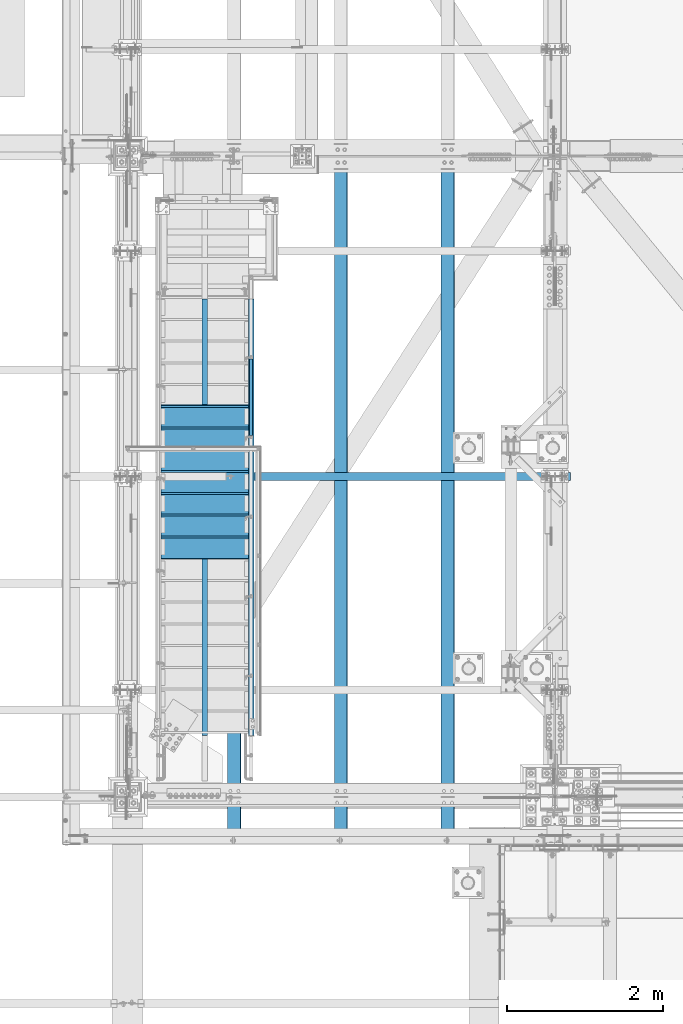
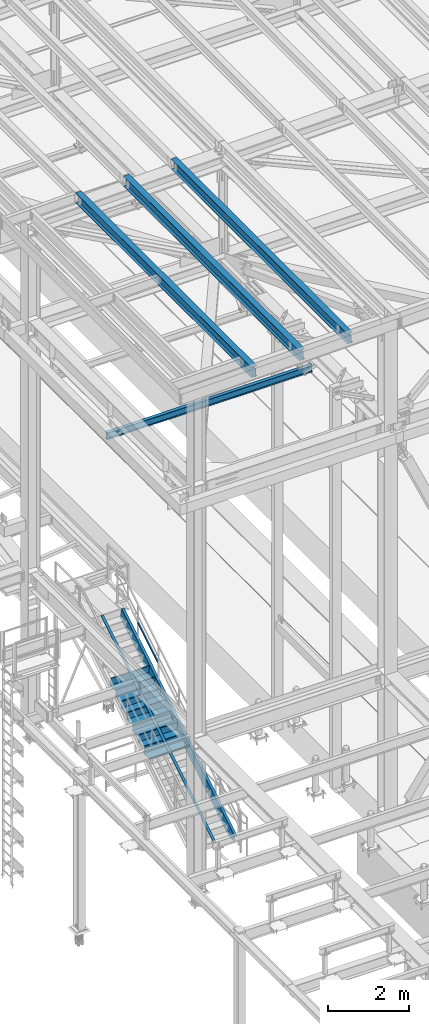
# One storey, part 1747 of 3843: 11 beams, 3 members, 7 elements without a shape of their own.
"""IFC2X3 building model written with IfcOpenShell, lengths in millimetres."""

from ifc_helpers import new_model, si_unit, frame, origin_with_axes, place, context, subcontext, project, spatial, faceted_brep, material, type_object, element, aggregate, save


model = new_model("IFC2X3")

# Units and contexts
model_context = context("Model", 3, precision=1e-05, world=origin_with_axes())
body_context = subcontext(model_context, "Body", "Model", "MODEL_VIEW")
ifc_project = project(units=[si_unit("LENGTHUNIT", "METRE", prefix="MILLI"), si_unit("AREAUNIT", "SQUARE_METRE"), si_unit("VOLUMEUNIT", "CUBIC_METRE"), si_unit("MASSUNIT", "GRAM", prefix="KILO"), si_unit("TIMEUNIT", "SECOND"), si_unit("PLANEANGLEUNIT", "RADIAN"), si_unit("SOLIDANGLEUNIT", "STERADIAN"), si_unit("THERMODYNAMICTEMPERATUREUNIT", "DEGREE_CELSIUS"), si_unit("LUMINOUSINTENSITYUNIT", "LUMEN")], contexts=[model_context])

# Site, building, storey
site_placement = place(None, origin_with_axes())
site = spatial("IfcSite", under=ifc_project, at=site_placement, CompositionType="ELEMENT")
building_placement = place(site_placement, origin_with_axes())
building = spatial("IfcBuilding", under=site, at=building_placement, Name="Undefined", CompositionType="ELEMENT")
storey_placement = place(building_placement, origin_with_axes())
storey = spatial("IfcBuildingStorey", under=building, at=storey_placement, Name="Undefined", CompositionType="ELEMENT", Elevation=0.0)

# Assembly, member
assembly_1_placement = place(storey_placement, origin_with_axes())
assembly_1 = element("IfcElementAssembly", 1, at=assembly_1_placement, inside=storey, Name="RAIL", AssemblyPlace="NOTDEFINED", PredefinedType="RIGID_FRAME")
ifc_material_1 = material()
member_type_1 = type_object("IfcMemberType", Name="HSS1-1/2X1-1/2X1/4", PredefinedType="NOTDEFINED")
member_1_placement = place(assembly_1_placement, frame((38163.499999927, 30238.7, 33562.6363637665), z_axis=(0.0, -0.529007926750979, 0.848616882600523), x_axis=(0.0, 0.848616882600524, 0.529007926750978)))
member_1 = element("IfcMember", 2, at=member_1_placement, type_object=member_type_1, material=ifc_material_1, Name="RAIL", ObjectType="HSS1-1/2X1-1/2X1/4", context=body_context, shape_type="Brep", body=[
    faceted_brep([(1194.15206246817, -19.0499999811145, 19.0499992336445), (1170.40141407416, -19.0499992350015, -19.0499992362566), (1170.40141407416, 19.0499992350015, -19.0499992362566), (1194.15206246817, 19.0499992350015, 19.0499992336445), (1190.19362096973, -12.6999993299978, 12.6999993286627), (1190.19362096973, 12.6999993299978, 12.6999993286627), (1174.35985557328, 12.6999993299978, -12.6999993312675), (1174.35985557328, -12.6999993299978, -12.6999993312675), (10.5729683018217, 19.0499992350015, -19.0499992349742), (34.3236166958304, 19.0499992350015, 19.0499992349305), (34.3236166958304, -19.0500000222455, 19.0499992349305), (10.5729683018217, -19.0499992350015, -19.0499992349742), (30.3651751973375, -12.6999993299978, 12.6999993299451), (14.5314098008821, -12.6999993299978, -12.6999993299924), (14.5314098008821, 12.6999993299978, -12.6999993299924), (30.3651751973375, 12.6999993299978, 12.6999993299451)], [[[0, 1, 2, 3], [4, 5, 6, 7]], [[8, 9, 3, 2]], [[9, 10, 0, 3]], [[10, 11, 1, 0]], [[11, 8, 2, 1]], [[10, 9, 8, 11], [12, 13, 14, 15]], [[13, 12, 4, 7]], [[14, 13, 7, 6]], [[15, 14, 6, 5]], [[12, 15, 5, 4]]]),
])
aggregate(assembly_1, [member_1])

assembly_2_placement = place(storey_placement, origin_with_axes())
assembly_2 = element("IfcElementAssembly", 3, at=assembly_2_placement, inside=storey, Name="STAIR", AssemblyPlace="NOTDEFINED", PredefinedType="RIGID_FRAME")
ifc_material_2 = material(Name="STEEL/A36")
member_type_2 = type_object("IfcMemberType", Name="C12X20.7", PredefinedType="NOTDEFINED")
member_2_placement = place(assembly_2_placement, frame((38163.5, 26304.1439046432, 30426.8707870968), z_axis=(0.0, -0.529007926750979, 0.848616882600523), x_axis=(0.0, 0.848616882600524, 0.529007926750978)))
member_2 = element("IfcMember", 4, at=member_2_placement, type_object=member_type_2, material=ifc_material_2, Name="STAIR", ObjectType="C12X20.7", context=body_context, shape_type="Brep", body=[
    faceted_brep([(340.480021051524, 30.1625000000058, -134.674927500528), (358.723458605898, -38.1000000000058, -146.047460000562), (6732.64031213429, -38.1000000000058, -146.04746000762), (6735.89472352868, 30.1625000000058, -134.674927507611), (368.913991523848, -38.1000000000058, -152.40000000058), (6730.82244275829, -38.1000000000058, -152.400000007619), (368.913991523848, 38.1000000000058, -152.40000000058), (6730.82244275829, 38.1000000000058, -152.400000007619), (6818.04528366987, -38.1000000000058, 152.399999992631), (6816.22741429387, -38.1000000000058, 146.047459992624), (6812.97300289948, 30.1625000000058, 134.674927492615), (6818.04528366987, 38.1000000000058, 152.399999992631), (211.84695601392, -38.1000000000058, 152.39999999994), (207.886931079338, -38.1000000000058, 146.047459999936), (200.797560171122, 30.1625000000058, 134.674927499931), (118.969711972852, 30.1625000000058, 3.40942099909807), (118.969711972852, 38.1000000000058, 3.40942099909807), (211.84695601392, 38.1000000000058, 152.39999999994)], [[[0, 1, 2, 3]], [[1, 4, 5, 2]], [[4, 6, 7, 5]], [[8, 9, 10, 3, 2, 5, 7, 11]], [[9, 8, 12, 13]], [[10, 9, 13, 14]], [[0, 3, 10, 14, 15]], [[6, 4, 1, 0, 15, 16]], [[11, 7, 6, 16, 17]], [[8, 11, 17, 12]], [[16, 15, 14, 13, 12, 17]]]),
])

# Assembly, beam
assembly_3_placement = place(storey_placement, origin_with_axes())
assembly_3 = element("IfcElementAssembly", 5, at=assembly_3_placement, inside=storey, Name="BEAM", AssemblyPlace="NOTDEFINED", PredefinedType="RIGID_FRAME")
ifc_material_3 = material(Name="STEEL/A992")
beam_type_1 = type_object("IfcBeamType", Name="W12X26", PredefinedType="NOTDEFINED")
beam_1_placement = place(assembly_3_placement, frame((40687.5092622718, 25006.2650649589, 45660.9713191839), z_axis=(-0.0211520975410968, -0.000224554000033095, 0.999776244139214), x_axis=(0.0, 0.999999974776521, 0.000224603999949863)))
beam_1 = element("IfcBeam", 6, at=beam_1_placement, type_object=beam_type_1, material=ifc_material_3, Name="BEAM", ObjectType="W12X26", context=body_context, shape_type="Brep", body=[
    faceted_brep([(20.6432194425361, -3.17499999977736, -130.175000003233), (20.6431892746732, 3.17500000020664, -130.175000003226), (77.7871087097046, 3.17500000020664, -130.175000002506), (77.7871087096828, -3.17499999977736, -130.175000002491), (82.6471882277765, 3.17500000020664, -131.141729925075), (82.6471882277547, -3.17499999978463, -131.141729925053), (86.767364695952, 3.17500000020664, -133.894743825527), (86.7673646959338, -3.17499999977736, -133.894743825498), (89.5203785964477, 3.17500000021391, -138.014920293645), (89.5203785964259, -3.17499999977008, -138.014920293623), (90.4871085190243, -3.1749999997628, -142.87499981164), (90.4871085190425, 3.17500000022119, -142.874999811655), (90.4871085193299, 3.17500000023574, -146.049999999443), (90.4871085193336, 82.5500000000975, -146.049999999501), (90.4871085193481, 82.550000000112, -155.57499999948), (90.4871085193408, -82.54999999961, -155.574999999364), (90.4871085193226, -82.54999999961, -146.049999999384), (90.4871085193299, -3.17499999975553, -146.049999999435), (8826.56834595945, -82.550000000505, 146.050000019059), (8826.57048483397, -82.5500000005268, 155.575000019031), (90.4871085147206, -82.5500000001266, 155.557908809169), (90.4871085147352, -82.5500000001048, 146.049999999916), (8826.56970046957, 82.549999999188, 155.575000018915), (90.4871085147315, 82.5499999995955, 155.574999999772), (8826.56756159505, 82.5499999992098, 146.050000018935), (90.4871085147461, 82.54999999961, 146.049999999792), (8826.56793869332, 3.17499999935535, 146.050000018993), (90.4871085147424, 3.17499999975553, 146.04999999985), (77.7871087051171, -3.17500000022119, 130.174999996096), (77.787108705139, 3.17499999977736, 130.174999996074), (20.7016518448945, 3.17499999978463, 130.174999995521), (20.7016820127574, -3.17500000021391, 130.174999995514), (82.6471882231817, -3.17500000021391, 131.141729918687), (82.6471882231963, 3.17499999977008, 131.141729918665), (86.7673646913427, -3.17500000022119, 133.894743819154), (86.7673646913609, 3.17499999977008, 133.894743819132), (89.5203785918275, -3.17500000022847, 138.014920287285), (89.5203785918493, 3.17499999977008, 138.014920287271), (90.4871085144187, -3.17500000022847, 142.874999805295), (90.4871085144332, 3.1749999997628, 142.874999805266), (90.4871085147424, -3.17500000023574, 146.04999999985), (8826.56796886118, -3.17500000064319, 146.050000019), (8826.50234654136, 3.17499999982101, -146.0499999803), (8826.50237670922, -3.17500000016298, -146.0499999803), (8826.50275380749, -82.5500000000247, -146.049999980249), (8826.50061493297, -82.5500000000102, -155.574999980214), (8826.49987298995, 82.5500000007232, -155.575000018347), (8826.50196944308, 82.54999999969, -146.049999980365), (20.6470195182665, 3.17500000018481, -113.117865577369), (20.6988016129581, 3.17499999980646, 117.482128609852)], [[[0, 1, 2, 3]], [[3, 2, 4, 5]], [[5, 4, 6, 7]], [[7, 6, 8, 9]], [[10, 11, 12, 13, 14, 15, 16, 17]], [[9, 8, 11, 10]], [[18, 19, 20, 21]], [[19, 22, 23, 20]], [[22, 24, 25, 23]], [[24, 26, 27, 25]], [[28, 29, 30, 31]], [[32, 33, 29, 28]], [[34, 35, 33, 32]], [[36, 37, 35, 34]], [[38, 39, 37, 36]], [[20, 23, 25, 27, 39, 38, 40, 21]], [[41, 18, 21, 40]], [[42, 26, 24, 22, 19, 18, 41, 43, 44, 45, 46, 47]], [[44, 43, 17, 16]], [[45, 44, 16, 15]], [[46, 45, 15, 14]], [[47, 46, 14, 13]], [[42, 47, 13, 12]], [[6, 4, 2, 1, 48, 49, 30, 29, 33, 35, 37, 39, 27, 26, 42, 12, 11, 8]], [[31, 30, 49, 48, 1, 0]], [[43, 41, 40, 38, 36, 34, 32, 28, 31, 0, 3, 5, 7, 9, 10, 17]]]),
])
aggregate(assembly_3, [beam_1])

assembly_4_placement = place(storey_placement, origin_with_axes())
assembly_4 = element("IfcElementAssembly", 7, at=assembly_4_placement, inside=storey, Name="BEAM", AssemblyPlace="NOTDEFINED", PredefinedType="RIGID_FRAME")
beam_2_placement = place(assembly_4_placement, frame((39315.9092622727, 25006.2767099549, 45631.9526113592), z_axis=(-0.0211520982443181, -0.000149703000020964, 0.999776258134226), x_axis=(0.0, 0.999999988789565, 0.000149735999968842)))
beam_2 = element("IfcBeam", 8, at=beam_2_placement, type_object=beam_type_1, material=ifc_material_3, Name="BEAM", ObjectType="W12X26", context=body_context, shape_type="Brep", body=[
    faceted_brep([(20.6413128908898, -3.17499999974098, -130.175000000403), (20.6412927789825, 3.17500000025029, -130.175000000381), (77.787239125093, 3.17500000024302, -130.175000000025), (77.7872391250785, -3.1749999997337, -130.174999999988), (82.6473186431285, 3.17500000025757, -131.14172992263), (82.647318643114, -3.1749999997337, -131.141729922587), (86.7674951112749, 3.17500000025757, -133.894743823133), (86.7674951112604, -3.1749999997337, -133.89474382309), (89.5205090117561, 3.17500000026484, -138.014920291324), (89.5205090117415, -3.17499999971915, -138.01492029128), (90.4872389343363, -3.17499999971187, -142.874999809348), (90.4872389343473, 3.17500000027212, -142.874999809399), (90.4872389345364, 3.1750000002794, -146.050000000265), (90.4872389345328, 82.5500000001484, -146.050000000447), (90.487238934511, 82.550000000163, -155.575000000463), (90.487238934511, -82.5499999995518, -155.575000000055), (90.4872389345401, -82.5499999995736, -146.050000000047), (90.4872389345328, -3.17499999971187, -146.050000000243), (8826.545514467, -82.5499999999593, 146.049999991854), (8826.5469403833, -82.5499999999738, 155.57499999187), (90.4872389378907, -82.5500000001557, 155.563607545781), (90.4872389379016, -82.5500000001339, 146.050000000294), (8826.54641747371, 82.549999999741, 155.57499999147), (90.4872389378834, 82.5499999995591, 155.574999999903), (8826.54499155741, 82.5499999997555, 146.049999991461), (90.4872389378979, 82.5499999995809, 146.049999999894), (8826.54524295625, 3.17499999990105, 146.04999999165), (90.4872389379016, 3.17499999972642, 146.05000000009), (77.7872391286583, -3.17500000023574, 130.175000000687), (77.7872391286764, 3.17499999975553, 130.175000000643), (20.6802678246204, 3.17499999974825, 130.174999999719), (20.6802879365277, -3.17500000023574, 130.174999999697), (82.6473186466756, -3.17500000023574, 131.141729923271), (82.6473186466901, 3.17499999974825, 131.141729923227), (86.7674951147928, -3.17500000025029, 133.894743823752), (86.767495114811, 3.17499999974825, 133.894743823708), (89.5205090152376, -3.17500000025757, 138.01492029192), (89.5205090152485, 3.1749999997337, 138.014920291876), (90.4872389377924, -3.17500000026484, 142.874999809981), (90.487238937807, 3.17499999971915, 142.874999809945), (90.4872389379016, -3.17500000026484, 146.050000000105), (8826.54526306816, -3.17500000009022, 146.049999991665), (8826.50151485627, 3.17500000045402, -146.050000008698), (8826.50153496817, -3.17499999953725, -146.050000008683), (8826.50178636701, -82.5499999993917, -146.050000008487), (8826.5003604507, -82.5499999993772, -155.575000008503), (8826.49987298995, 82.5500000007232, -155.575000018347), (8826.50126345742, 82.5500000003303, -146.050000008894), (20.643845918461, 3.17500000022119, -113.120244767728), (20.6783673143655, 3.17499999977736, 117.479752649408)], [[[0, 1, 2, 3]], [[3, 2, 4, 5]], [[5, 4, 6, 7]], [[7, 6, 8, 9]], [[10, 11, 12, 13, 14, 15, 16, 17]], [[9, 8, 11, 10]], [[18, 19, 20, 21]], [[19, 22, 23, 20]], [[22, 24, 25, 23]], [[24, 26, 27, 25]], [[28, 29, 30, 31]], [[32, 33, 29, 28]], [[34, 35, 33, 32]], [[36, 37, 35, 34]], [[38, 39, 37, 36]], [[20, 23, 25, 27, 39, 38, 40, 21]], [[41, 18, 21, 40]], [[42, 26, 24, 22, 19, 18, 41, 43, 44, 45, 46, 47]], [[44, 43, 17, 16]], [[45, 44, 16, 15]], [[46, 45, 15, 14]], [[47, 46, 14, 13]], [[42, 47, 13, 12]], [[6, 4, 2, 1, 48, 49, 30, 29, 33, 35, 37, 39, 27, 26, 42, 12, 11, 8]], [[31, 30, 49, 48, 1, 0]], [[43, 41, 40, 38, 36, 34, 32, 28, 31, 0, 3, 5, 7, 9, 10, 17]]]),
])
aggregate(assembly_4, [beam_2])

assembly_5_placement = place(storey_placement, origin_with_axes())
assembly_5 = element("IfcElementAssembly", 9, at=assembly_5_placement, inside=storey, Name="BEAM", AssemblyPlace="NOTDEFINED", PredefinedType="RIGID_FRAME")
beam_3_placement = place(assembly_5_placement, frame((37944.3092622731, 25006.2883549503, 45602.9339026668), z_axis=(-0.0211520980666537, -7.48509999611997e-05, 0.999776266544024), x_axis=(0.0, 0.999999997197391, 7.4868000015057e-05)))
beam_3 = element("IfcBeam", 10, at=beam_3_placement, type_object=beam_type_1, material=ifc_material_3, Name="BEAM", ObjectType="W12X26", context=body_context, shape_type="Brep", body=[
    faceted_brep([(20.639406454884, -3.17500000043947, -130.174999999246), (20.6393963989321, 3.17499999954453, -130.174999999268), (77.7873696680799, 3.17499999954453, -130.174999999668), (77.7873696680726, -3.17500000044674, -130.174999999719), (82.6474491861336, 3.17499999954453, -131.141729922223), (82.64744918613, -3.17500000045402, -131.141729922281), (86.7676256542945, 3.17499999952997, -133.894743822668), (86.7676256542873, -3.1750000004613, -133.894743822719), (89.5206395547721, 3.17499999951542, -138.014920290785), (89.5206395547684, -3.17500000047585, -138.014920290836), (90.4873694773523, -3.17500000048312, -142.874999808861), (90.487369477356, 3.17499999950087, -142.874999808795), (90.4873694774578, 3.17499999947904, -146.049999999537), (90.4873694774615, 82.5499999993262, -146.049999999312), (90.4873694774979, 82.5499999992899, -155.574999999299), (90.4873694774906, -82.550000000374, -155.574999999757), (90.4873694774506, -82.5500000003376, -146.04999999977), (90.4873694774542, -3.17500000050495, -146.049999999552), (8826.52273256387, -82.5499999999229, 146.050000027171), (8826.52344552206, -82.5499999998865, 155.575000027151), (90.4873694782764, -82.5499999993117, 155.569304564633), (90.4873694782837, -82.5499999993481, 146.049999999879), (8826.52318406725, 82.5499999997701, 155.575000027617), (90.4873694782873, 82.5500000003522, 155.575000000339), (8826.52247110907, 82.549999999741, 146.05000002763), (90.4873694782909, 82.5500000003158, 146.050000000345), (8826.5225968085, 3.17499999990105, 146.050000027404), (90.4873694782837, 3.17500000048312, 146.050000000119), (77.7873696687093, -3.17499999955908, 130.17499999977), (77.7873696687129, 3.17500000042492, 130.174999999828), (20.6588839225406, 3.17500000043219, 130.175000000956), (20.6588939784961, -3.17499999955908, 130.175000000978), (82.6474491867702, -3.17499999956635, 131.141729922376), (82.6474491867775, 3.17500000043219, 131.141729922427), (86.7676256549457, -3.17499999954453, 133.894743822857), (86.7676256549566, 3.17500000043219, 133.894743822908), (89.5206395554524, -3.17499999953725, 138.014920290996), (89.5206395554596, 3.17500000045402, 138.014920291062), (90.4873694780617, -3.1749999995227, 142.874999809028), (90.4873694780727, 3.17500000046857, 142.874999809086), (90.4873694782873, -3.17499999950087, 146.050000000097), (8826.52260686445, -3.17500000008295, 146.05000002739), (8826.50073275761, 3.17499999890424, -146.049999972245), (8826.50074281357, -3.17500000107975, -146.04999997226), (8826.500868513, -82.5500000009197, -146.049999972485), (8826.50015555482, -82.5500000009488, -155.574999972465), (8826.49987298995, 82.5500000007232, -155.575000018347), (8826.50060705819, 82.5499999987442, -146.04999997202), (20.6406727907161, 3.17499999960273, -113.12262292076), (20.6579334895105, 3.17500000038854, 117.47737642545)], [[[0, 1, 2, 3]], [[3, 2, 4, 5]], [[5, 4, 6, 7]], [[7, 6, 8, 9]], [[10, 11, 12, 13, 14, 15, 16, 17]], [[9, 8, 11, 10]], [[18, 19, 20, 21]], [[19, 22, 23, 20]], [[22, 24, 25, 23]], [[24, 26, 27, 25]], [[28, 29, 30, 31]], [[32, 33, 29, 28]], [[34, 35, 33, 32]], [[36, 37, 35, 34]], [[38, 39, 37, 36]], [[20, 23, 25, 27, 39, 38, 40, 21]], [[41, 18, 21, 40]], [[42, 26, 24, 22, 19, 18, 41, 43, 44, 45, 46, 47]], [[44, 43, 17, 16]], [[45, 44, 16, 15]], [[46, 45, 15, 14]], [[47, 46, 14, 13]], [[42, 47, 13, 12]], [[6, 4, 2, 1, 48, 49, 30, 29, 33, 35, 37, 39, 27, 26, 42, 12, 11, 8]], [[31, 30, 49, 48, 1, 0]], [[43, 41, 40, 38, 36, 34, 32, 28, 31, 0, 3, 5, 7, 9, 10, 17]]]),
])
aggregate(assembly_5, [beam_3])

# Assembly, member
assembly_6_placement = place(storey_placement, origin_with_axes())
assembly_6 = element("IfcElementAssembly", 11, at=assembly_6_placement, inside=storey, Name="ref.", AssemblyPlace="NOTDEFINED", PredefinedType="RIGID_FRAME")
ifc_material_4 = material(Name="STEEL/Steel_Undefined")
member_type_3 = type_object("IfcMemberType", PredefinedType="NOTDEFINED")
member_3_placement = place(assembly_6_placement, frame((37566.5999999524, 26404.9796001673, 30665.5743608276), z_axis=(-1.0, 0.0, 0.0), x_axis=(0.0, 0.848616882600524, 0.529007926750978)))
member_3 = element("IfcMember", 12, at=member_3_placement, type_object=member_type_3, material=ifc_material_4, Name="ref.", context=body_context, shape_type="Brep", body=[
    faceted_brep([(0.0, 3.17500000000291, -38.0999999999985), (0.0, 3.17500000000291, 38.0999999999985), (6606.19832683169, 3.17500000731343, 38.0999999999985), (6606.19832683169, 3.17500000731343, -38.0999999999985), (0.0, -3.17500000000291, 38.0999999999985), (6606.1983268317, -3.17499999269603, 38.0999999999985), (0.0, -3.17500000000291, -38.0999999999985), (6606.1983268317, -3.17499999269603, -38.0999999999985)], [[[0, 1, 2, 3]], [[1, 4, 5, 2]], [[4, 6, 7, 5]], [[6, 0, 3, 7]], [[5, 7, 3, 2]], [[6, 4, 1, 0]]]),
])
aggregate(assembly_6, [member_3])

# Beam
ifc_material_5 = material(Name="STEEL/ASTM A1011")
beam_type_2 = type_object("IfcBeamType", PredefinedType="NOTDEFINED")
beam_4_placement = place(assembly_2_placement, frame((37566.5999999524, 30645.0999999828, 33265.1553571485), z_axis=(1.0, 0.0, 0.0), x_axis=(0.0, -1.0, 0.0)))
beam_4 = element("IfcBeam", 13, at=beam_4_placement, type_object=beam_type_2, material=ifc_material_5, Name="TREAD", context=body_context, shape_type="Brep", body=[
    faceted_brep([(0.0, -1.58750000000146, -558.799999999999), (0.0, -1.58750000000146, 558.799999999999), (0.0, 1.58750000000146, 558.799999999999), (0.0, 1.58750000000146, -558.799999999999), (21.7283948539116, 1.58750000000146, 558.800000000003), (21.7283948539116, 1.58750000000146, -558.800000000003), (25.3999999999942, -1.58750000000146, -558.799999999999), (25.3999999999942, -1.58750000000146, 558.799999999999), (-11.0799384794227, 226.55892857143, 558.800000000003), (-11.0799384794227, 226.55892857143, -558.800000000003), (-7.40833333332557, 223.383928571428, -558.800000000003), (-7.40833333332557, 223.383928571428, 558.800000000003), (293.720061520566, 226.55892857143, 558.800000000003), (293.720061520566, 226.55892857143, -558.800000000003), (290.974498041134, 223.383928571428, -558.800000000003), (290.974498041134, 223.383928571428, 558.800000000003), (299.614357882056, 186.140896378427, 558.800000000003), (299.614357882056, 186.140896378427, -558.800000000003), (296.472590667174, 185.682721992918, 558.800000000003), (296.472590667174, 185.682721992918, -558.800000000003)], [[[0, 1, 2, 3]], [[3, 2, 4, 5]], [[1, 0, 6, 7]], [[5, 4, 8, 9]], [[7, 6, 10, 11]], [[9, 8, 12, 13]], [[11, 10, 14, 15]], [[13, 12, 16, 17]], [[12, 8, 4, 2, 1, 7, 11, 15, 18, 16]], [[15, 14, 19, 18]], [[14, 10, 6, 0, 3, 5, 9, 13, 17, 19]], [[18, 19, 17, 16]]]),
])

beam_5_placement = place(assembly_2_placement, frame((37566.5999999524, 30365.699999982, 33090.9839285771), z_axis=(1.0, 0.0, 0.0), x_axis=(0.0, -1.0, 0.0)))
beam_5 = element("IfcBeam", 14, at=beam_5_placement, type_object=beam_type_2, material=ifc_material_5, Name="TREAD", context=body_context, shape_type="Brep", body=[
    faceted_brep([(0.0, -1.58750000000146, -558.799999999999), (0.0, -1.58750000000146, 558.799999999999), (0.0, 1.58750000000146, 558.799999999999), (0.0, 1.58750000000146, -558.799999999999), (21.7283948539116, 1.58750000000146, 558.800000000003), (21.7283948539116, 1.58750000000146, -558.800000000003), (25.3999999999942, -1.58750000000146, -558.799999999999), (25.3999999999942, -1.58750000000146, 558.799999999999), (-11.0799384794227, 226.55892857143, 558.800000000003), (-11.0799384794227, 226.55892857143, -558.800000000003), (-7.40833333332557, 223.383928571428, -558.800000000003), (-7.40833333332557, 223.383928571428, 558.800000000003), (293.720061520566, 226.55892857143, 558.800000000003), (293.720061520566, 226.55892857143, -558.800000000003), (290.974498041134, 223.383928571428, -558.800000000003), (290.974498041134, 223.383928571428, 558.800000000003), (299.614357882056, 186.140896378427, 558.800000000003), (299.614357882056, 186.140896378427, -558.800000000003), (296.472590667174, 185.682721992918, 558.800000000003), (296.472590667174, 185.682721992918, -558.800000000003)], [[[0, 1, 2, 3]], [[3, 2, 4, 5]], [[1, 0, 6, 7]], [[5, 4, 8, 9]], [[7, 6, 10, 11]], [[9, 8, 12, 13]], [[11, 10, 14, 15]], [[13, 12, 16, 17]], [[12, 8, 4, 2, 1, 7, 11, 15, 18, 16]], [[15, 14, 19, 18]], [[14, 10, 6, 0, 3, 5, 9, 13, 17, 19]], [[18, 19, 17, 16]]]),
])

beam_6_placement = place(assembly_2_placement, frame((37566.5999999524, 30086.2999999812, 32916.8125000057), z_axis=(1.0, 0.0, 0.0), x_axis=(0.0, -1.0, 0.0)))
beam_6 = element("IfcBeam", 15, at=beam_6_placement, type_object=beam_type_2, material=ifc_material_5, Name="TREAD", context=body_context, shape_type="Brep", body=[
    faceted_brep([(0.0, -1.58750000000146, -558.799999999999), (0.0, -1.58750000000146, 558.799999999999), (0.0, 1.58750000000146, 558.799999999999), (0.0, 1.58750000000146, -558.799999999999), (21.7283948539116, 1.58750000000146, 558.800000000003), (21.7283948539116, 1.58750000000146, -558.800000000003), (25.3999999999942, -1.58750000000146, -558.799999999999), (25.3999999999942, -1.58750000000146, 558.799999999999), (-11.0799384794227, 226.55892857143, 558.800000000003), (-11.0799384794227, 226.55892857143, -558.800000000003), (-7.40833333332557, 223.383928571428, -558.800000000003), (-7.40833333332557, 223.383928571428, 558.800000000003), (293.720061520566, 226.55892857143, 558.800000000003), (293.720061520566, 226.55892857143, -558.800000000003), (290.974498041134, 223.383928571428, -558.800000000003), (290.974498041134, 223.383928571428, 558.800000000003), (299.614357882056, 186.140896378427, 558.800000000003), (299.614357882056, 186.140896378427, -558.800000000003), (296.472590667174, 185.682721992918, 558.800000000003), (296.472590667174, 185.682721992918, -558.800000000003)], [[[0, 1, 2, 3]], [[3, 2, 4, 5]], [[1, 0, 6, 7]], [[5, 4, 8, 9]], [[7, 6, 10, 11]], [[9, 8, 12, 13]], [[11, 10, 14, 15]], [[13, 12, 16, 17]], [[12, 8, 4, 2, 1, 7, 11, 15, 18, 16]], [[15, 14, 19, 18]], [[14, 10, 6, 0, 3, 5, 9, 13, 17, 19]], [[18, 19, 17, 16]]]),
])

beam_7_placement = place(assembly_2_placement, frame((37566.5999999524, 29806.8999999812, 32742.6410714342), z_axis=(1.0, 0.0, 0.0), x_axis=(0.0, -1.0, 0.0)))
beam_7 = element("IfcBeam", 16, at=beam_7_placement, type_object=beam_type_2, material=ifc_material_5, Name="TREAD", context=body_context, shape_type="Brep", body=[
    faceted_brep([(0.0, -1.58750000000146, -558.799999999999), (0.0, -1.58750000000146, 558.799999999999), (0.0, 1.58750000000146, 558.799999999999), (0.0, 1.58750000000146, -558.799999999999), (21.7283948539116, 1.58750000000146, 558.800000000003), (21.7283948539116, 1.58750000000146, -558.800000000003), (25.3999999999942, -1.58750000000146, -558.799999999999), (25.3999999999942, -1.58750000000146, 558.799999999999), (-11.0799384794227, 226.55892857143, 558.800000000003), (-11.0799384794227, 226.55892857143, -558.800000000003), (-7.40833333332557, 223.383928571428, -558.800000000003), (-7.40833333332557, 223.383928571428, 558.800000000003), (293.720061520566, 226.55892857143, 558.800000000003), (293.720061520566, 226.55892857143, -558.800000000003), (290.974498041134, 223.383928571428, -558.800000000003), (290.974498041134, 223.383928571428, 558.800000000003), (299.614357882056, 186.140896378427, 558.800000000003), (299.614357882056, 186.140896378427, -558.800000000003), (296.472590667174, 185.682721992918, 558.800000000003), (296.472590667174, 185.682721992918, -558.800000000003)], [[[0, 1, 2, 3]], [[3, 2, 4, 5]], [[1, 0, 6, 7]], [[5, 4, 8, 9]], [[7, 6, 10, 11]], [[9, 8, 12, 13]], [[11, 10, 14, 15]], [[13, 12, 16, 17]], [[12, 8, 4, 2, 1, 7, 11, 15, 18, 16]], [[15, 14, 19, 18]], [[14, 10, 6, 0, 3, 5, 9, 13, 17, 19]], [[18, 19, 17, 16]]]),
])

beam_8_placement = place(assembly_2_placement, frame((37566.5999999524, 29527.4999999812, 32568.4696428628), z_axis=(1.0, 0.0, 0.0), x_axis=(0.0, -1.0, 0.0)))
beam_8 = element("IfcBeam", 17, at=beam_8_placement, type_object=beam_type_2, material=ifc_material_5, Name="TREAD", context=body_context, shape_type="Brep", body=[
    faceted_brep([(0.0, -1.58750000000146, -558.799999999999), (0.0, -1.58750000000146, 558.799999999999), (0.0, 1.58750000000146, 558.799999999999), (0.0, 1.58750000000146, -558.799999999999), (21.7283948539116, 1.58750000000146, 558.800000000003), (21.7283948539116, 1.58750000000146, -558.800000000003), (25.3999999999942, -1.58750000000146, -558.799999999999), (25.3999999999942, -1.58750000000146, 558.799999999999), (-11.0799384794227, 226.55892857143, 558.800000000003), (-11.0799384794227, 226.55892857143, -558.800000000003), (-7.40833333332557, 223.383928571428, -558.800000000003), (-7.40833333332557, 223.383928571428, 558.800000000003), (293.720061520566, 226.55892857143, 558.800000000003), (293.720061520566, 226.55892857143, -558.800000000003), (290.974498041134, 223.383928571428, -558.800000000003), (290.974498041134, 223.383928571428, 558.800000000003), (299.614357882056, 186.140896378427, 558.800000000003), (299.614357882056, 186.140896378427, -558.800000000003), (296.472590667174, 185.682721992918, 558.800000000003), (296.472590667174, 185.682721992918, -558.800000000003)], [[[0, 1, 2, 3]], [[3, 2, 4, 5]], [[1, 0, 6, 7]], [[5, 4, 8, 9]], [[7, 6, 10, 11]], [[9, 8, 12, 13]], [[11, 10, 14, 15]], [[13, 12, 16, 17]], [[12, 8, 4, 2, 1, 7, 11, 15, 18, 16]], [[15, 14, 19, 18]], [[14, 10, 6, 0, 3, 5, 9, 13, 17, 19]], [[18, 19, 17, 16]]]),
])

beam_9_placement = place(assembly_2_placement, frame((37566.5999999524, 29248.0999999812, 32394.2982142914), z_axis=(1.0, 0.0, 0.0), x_axis=(0.0, -1.0, 0.0)))
beam_9 = element("IfcBeam", 18, at=beam_9_placement, type_object=beam_type_2, material=ifc_material_5, Name="TREAD", context=body_context, shape_type="Brep", body=[
    faceted_brep([(0.0, -1.58750000000146, -558.799999999999), (0.0, -1.58750000000146, 558.799999999999), (0.0, 1.58750000000146, 558.799999999999), (0.0, 1.58750000000146, -558.799999999999), (21.7283948539116, 1.58750000000146, 558.800000000003), (21.7283948539116, 1.58750000000146, -558.800000000003), (25.3999999999942, -1.58750000000146, -558.799999999999), (25.3999999999942, -1.58750000000146, 558.799999999999), (-11.0799384794227, 226.55892857143, 558.800000000003), (-11.0799384794227, 226.55892857143, -558.800000000003), (-7.40833333332557, 223.383928571428, -558.800000000003), (-7.40833333332557, 223.383928571428, 558.800000000003), (293.720061520566, 226.55892857143, 558.800000000003), (293.720061520566, 226.55892857143, -558.800000000003), (290.974498041134, 223.383928571428, -558.800000000003), (290.974498041134, 223.383928571428, 558.800000000003), (299.614357882056, 186.140896378427, 558.800000000003), (299.614357882056, 186.140896378427, -558.800000000003), (296.472590667174, 185.682721992918, 558.800000000003), (296.472590667174, 185.682721992918, -558.800000000003)], [[[0, 1, 2, 3]], [[3, 2, 4, 5]], [[1, 0, 6, 7]], [[5, 4, 8, 9]], [[7, 6, 10, 11]], [[9, 8, 12, 13]], [[11, 10, 14, 15]], [[13, 12, 16, 17]], [[12, 8, 4, 2, 1, 7, 11, 15, 18, 16]], [[15, 14, 19, 18]], [[14, 10, 6, 0, 3, 5, 9, 13, 17, 19]], [[18, 19, 17, 16]]]),
])

beam_10_placement = place(assembly_2_placement, frame((37566.5999999524, 28968.6999999812, 32220.1267857199), z_axis=(1.0, 0.0, 0.0), x_axis=(0.0, -1.0, 0.0)))
beam_10 = element("IfcBeam", 19, at=beam_10_placement, type_object=beam_type_2, material=ifc_material_5, Name="TREAD", context=body_context, shape_type="Brep", body=[
    faceted_brep([(0.0, -1.58750000000146, -558.799999999999), (0.0, -1.58750000000146, 558.799999999999), (0.0, 1.58750000000146, 558.799999999999), (0.0, 1.58750000000146, -558.799999999999), (21.7283948539116, 1.58750000000146, 558.800000000003), (21.7283948539116, 1.58750000000146, -558.800000000003), (25.3999999999942, -1.58750000000146, -558.799999999999), (25.3999999999942, -1.58750000000146, 558.799999999999), (-11.0799384794227, 226.55892857143, 558.800000000003), (-11.0799384794227, 226.55892857143, -558.800000000003), (-7.40833333332557, 223.383928571428, -558.800000000003), (-7.40833333332557, 223.383928571428, 558.800000000003), (293.720061520566, 226.55892857143, 558.800000000003), (293.720061520566, 226.55892857143, -558.800000000003), (290.974498041134, 223.383928571428, -558.800000000003), (290.974498041134, 223.383928571428, 558.800000000003), (299.614357882056, 186.140896378427, 558.800000000003), (299.614357882056, 186.140896378427, -558.800000000003), (296.472590667174, 185.682721992918, 558.800000000003), (296.472590667174, 185.682721992918, -558.800000000003)], [[[0, 1, 2, 3]], [[3, 2, 4, 5]], [[1, 0, 6, 7]], [[5, 4, 8, 9]], [[7, 6, 10, 11]], [[9, 8, 12, 13]], [[11, 10, 14, 15]], [[13, 12, 16, 17]], [[12, 8, 4, 2, 1, 7, 11, 15, 18, 16]], [[15, 14, 19, 18]], [[14, 10, 6, 0, 3, 5, 9, 13, 17, 19]], [[18, 19, 17, 16]]]),
])

aggregate(assembly_2, [beam_4, beam_5, beam_6, beam_7, beam_8, beam_9, beam_10, member_2])

# Assembly, beam
assembly_7_placement = place(storey_placement, origin_with_axes())
assembly_7 = element("IfcElementAssembly", 20, at=assembly_7_placement, inside=storey, Name="BEAM", AssemblyPlace="NOTDEFINED", PredefinedType="RIGID_FRAME")
beam_type_3 = type_object("IfcBeamType", Name="W8X13", PredefinedType="NOTDEFINED")
beam_11_placement = place(assembly_7_placement, frame((36372.8, 29730.7, 41402.0), z_axis=(0.0, 0.0, 1.0), x_axis=(1.0, 0.0, 0.0)))
beam_11 = element("IfcBeam", 21, at=beam_11_placement, type_object=beam_type_3, material=ifc_material_3, Name="BEAM", ObjectType="W8X13", context=body_context, shape_type="Brep", body=[
    faceted_brep([(0.0, 50.7999999999993, -101.599999999999), (0.0, 50.7999999999993, -95.25), (5892.8, 50.7999999999993, -95.25), (5892.8, 50.7999999999993, -101.599999999999), (0.0, 3.17499999999927, -95.25), (5892.8, 3.17499999999927, -95.25), (-2.44140610448085e-05, 3.17500000000291, 95.2499999999927), (5892.8, 3.17499999999927, 95.25), (0.0, 50.7999999999993, 95.25), (5892.8, 50.7999999999993, 95.25), (0.0, 50.7999999999993, 101.599999999999), (5892.8, 50.7999999999993, 101.599999999999), (0.0, -50.7999999999993, 101.599999999999), (5892.8, -50.7999999999993, 101.599999999999), (0.0, -50.7999999999993, 95.25), (5892.8, -50.7999999999993, 95.25), (0.0, -3.17499999999927, 95.25), (5892.8, -3.17499999999927, 95.25), (0.0, -3.17499999999927, -95.25), (5892.8, -3.17499999999927, -95.25), (0.0, -50.7999999999993, -95.25), (5892.8, -50.7999999999993, -95.25), (0.0, -50.7999999999993, -101.599999999999), (5892.8, -50.7999999999993, -101.599999999999)], [[[0, 1, 2, 3]], [[1, 4, 5, 2]], [[4, 6, 7, 5]], [[6, 8, 9, 7]], [[8, 10, 11, 9]], [[10, 12, 13, 11]], [[12, 14, 15, 13]], [[14, 16, 17, 15]], [[16, 18, 19, 17]], [[18, 20, 21, 19]], [[20, 22, 23, 21]], [[22, 0, 3, 23]], [[5, 7, 9, 11, 13, 15, 17, 19, 21, 23, 3, 2]], [[22, 20, 18, 16, 14, 12, 10, 8, 6, 4, 1, 0]]]),
])
aggregate(assembly_7, [beam_11])

save(model, "model.ifc")
